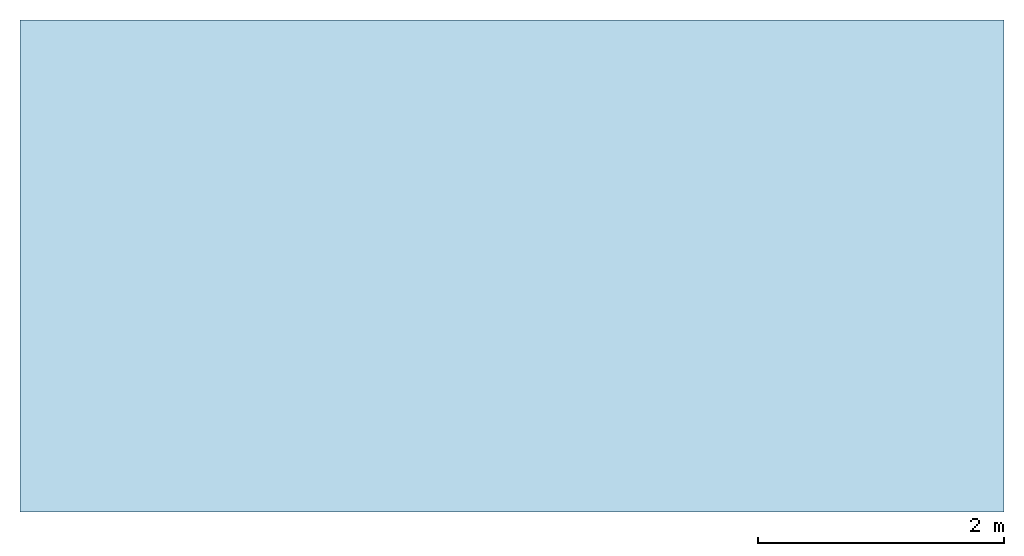
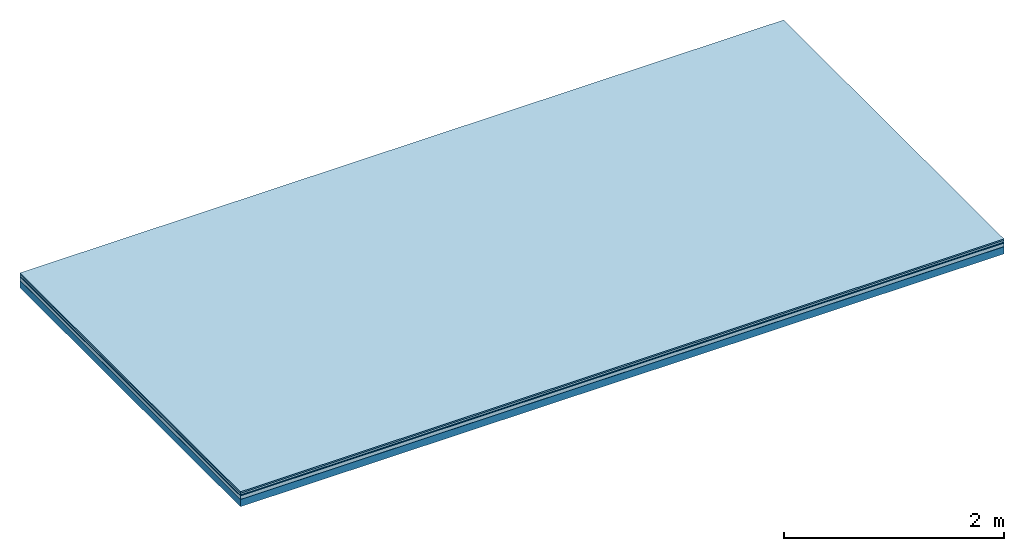
# One storey: 5 plates, 1 member, 1 element without a shape of its own.
"""IFC4 building model written with IfcOpenShell, lengths in metres."""

import ifcopenshell
import ifcopenshell.guid

model = None  # the IFC model being written
_history = None  # IfcOwnerHistory: only IFC2X3 demands one
_inside = {}  # id of a spatial element -> (the spatial element, [elements in it])
_under = {}  # id of a project, library or spatial element -> (it, [spatial elements below it])
_declared = {}  # id of a project -> (the project, [libraries it declares])
_typed = {}  # id of a type object -> (the type object, [elements of that type])
_made_of = {}  # id of a material, layer set ... -> (it, [elements and type objects made of it])


def new_model(schema):
    """Start an empty IFC model of exactly this schema.

    Asked for "IFC4X3", IfcOpenShell would pick the latest addendum, in which some entities
    have other attributes; the version numbers below select the first issue.
    IFC2X3 requires an IfcOwnerHistory on every rooted entity: one is made here for all.
    """
    global model, _history
    if schema == "IFC4X3":
        model = ifcopenshell.file(schema_version=(4, 3, 0, 0))
    else:
        model = ifcopenshell.file(schema=schema)
    _inside.clear()
    _under.clear()
    _declared.clear()
    _typed.clear()
    _made_of.clear()
    _history = None
    if model.schema == "IFC2X3":
        org = make("IfcOrganization", Name="unknown")
        user = make(
            "IfcPersonAndOrganization",
            ThePerson=make("IfcPerson", FamilyName="unknown"),
            TheOrganization=org,
        )
        app = make(
            "IfcApplication",
            ApplicationDeveloper=org,
            Version="unknown",
            ApplicationFullName="unknown",
            ApplicationIdentifier="unknown",
        )
        _history = make(
            "IfcOwnerHistory",
            OwningUser=user,
            OwningApplication=app,
            ChangeAction="ADDED",
            CreationDate=0,
        )
    return model


def make(cls, **values):
    """One entity of the class cls with the attributes given. An attribute that is None is left unset."""
    return model.create_entity(
        cls, **{name: value for name, value in values.items() if value is not None}
    )


def rooted(cls, **values):
    """An entity with a GlobalId (a new one), such as an element, a storey or a relation."""
    return make(cls, GlobalId=ifcopenshell.guid.new(), OwnerHistory=_history, **values)


def si_unit(unit_type, name, prefix=None):
    """IfcSIUnit, for example si_unit("LENGTHUNIT", "METRE", prefix="MILLI")."""
    return make("IfcSIUnit", UnitType=unit_type, Prefix=prefix, Name=name)


def derived_unit(unit_type, elements):
    """IfcDerivedUnit: a product of units, each with its exponent."""
    return make(
        "IfcDerivedUnit",
        Elements=[
            make("IfcDerivedUnitElement", Unit=unit, Exponent=power)
            for unit, power in elements
        ],
        UnitType=unit_type,
    )


def assignment(units):
    """IfcUnitAssignment: the units of a project."""
    return None if units is None else make("IfcUnitAssignment", Units=units)


def point(xyz):
    """IfcCartesianPoint."""
    return None if xyz is None else make("IfcCartesianPoint", Coordinates=xyz)


def direction(xyz):
    """IfcDirection."""
    return None if xyz is None else make("IfcDirection", DirectionRatios=xyz)


def frame(location, z_axis=None, x_axis=None):
    """IfcAxis2Placement3D, a coordinate frame: its origin and axes. An axis left out is left unset."""
    return make(
        "IfcAxis2Placement3D",
        Location=point(location),
        Axis=direction(z_axis),
        RefDirection=direction(x_axis),
    )


def frame_2d(location, x_axis=None):
    """IfcAxis2Placement2D, a coordinate frame in the plane: its origin and x axis."""
    return make(
        "IfcAxis2Placement2D", Location=point(location), RefDirection=direction(x_axis)
    )


def origin():
    """The frame at (0, 0, 0) with its axes left unset."""
    return frame((0.0, 0.0, 0.0))


def origin_with_axes():
    """The frame at (0, 0, 0) with the z axis (0, 0, 1) and the x axis (1, 0, 0) written out."""
    return frame((0.0, 0.0, 0.0), z_axis=(0.0, 0.0, 1.0), x_axis=(1.0, 0.0, 0.0))


def place(relative_to, where):
    """IfcLocalPlacement: puts the frame where relative to a parent placement (None: the world)."""
    return make(
        "IfcLocalPlacement", PlacementRelTo=relative_to, RelativePlacement=where
    )


def context(
    kind, dimensions, precision=None, world=None, true_north=None, identifier=None
):
    """IfcGeometricRepresentationContext, for example the 3D "Model" context."""
    return make(
        "IfcGeometricRepresentationContext",
        ContextIdentifier=identifier,
        ContextType=kind,
        CoordinateSpaceDimension=dimensions,
        Precision=precision,
        WorldCoordinateSystem=world,
        TrueNorth=true_north,
    )


def project(units=None, contexts=None):
    """IfcProject with its units and contexts."""
    return rooted(
        "IfcProject",
        Name="project",
        RepresentationContexts=contexts,
        UnitsInContext=assignment(units),
    )


def spatial(cls, under=None, at=None, **own):
    """A site, building, storey or space (cls), placed at a placement, below another one or the project."""
    s = rooted(cls, ObjectPlacement=at, **own)
    if under is not None:
        _under.setdefault(under.id(), (under, []))[1].append(s)
    return s


def profile(cls, at=None, kind="AREA", **sizes):
    """A parametric profile (cls). Its sizes go by their IFC names, for example OverallWidth=200.0."""
    return make(cls, ProfileType=kind, Position=at, **sizes)


def rectangle(**sizes):
    """IfcRectangleProfileDef."""
    return profile("IfcRectangleProfileDef", **sizes)


def extrude(swept, where, along, depth):
    """IfcExtrudedAreaSolid: the profile swept, set in the frame where, extruded along a direction by depth."""
    return make(
        "IfcExtrudedAreaSolid",
        SweptArea=swept,
        Position=where,
        ExtrudedDirection=direction(along),
        Depth=depth,
    )


def shape(context_of_items, identifier, shape_type, items):
    """IfcShapeRepresentation: the items that make up one representation, for example the "Body"."""
    return make(
        "IfcShapeRepresentation",
        ContextOfItems=context_of_items,
        RepresentationIdentifier=identifier,
        RepresentationType=shape_type,
        Items=items,
    )


def material(Name=None, Category=None):
    """IfcMaterial."""
    return make("IfcMaterial", Name=Name, Category=Category)


def layer(
    of_material, thickness, ventilated=None, Name=None, Category=None, Priority=None
):
    """IfcMaterialLayer: one layer of a wall or slab, of a material (None: an air gap)."""
    return make(
        "IfcMaterialLayer",
        Material=of_material,
        LayerThickness=thickness,
        IsVentilated=ventilated,
        Name=Name,
        Category=Category,
        Priority=Priority,
    )


def layer_set(layers, Name=None):
    """IfcMaterialLayerSet."""
    return make("IfcMaterialLayerSet", MaterialLayers=layers, LayerSetName=Name)


def made_of(thing, what):
    """Note that an element or type object is made of a material, layer set ...; save() writes the relation."""
    if what is not None:
        _made_of.setdefault(what.id(), (what, []))[1].append(thing)
    return thing


def type_object(cls, material=None, **own):
    """A type object (cls), such as IfcWallType, which elements share."""
    return made_of(rooted(cls, **own), material)


def element(
    cls,
    number,
    at=None,
    inside=None,
    cuts=None,
    type_object=None,
    material=None,
    context=None,
    identifier="Body",
    shape_type=None,
    held_by="IfcProductDefinitionShape",
    body=None,
    shapes=None,
    **own,
):
    """One element of the class cls, such as IfcWall. Its Tag is "e" and its number.

    at: its placement. inside: the storey or other place that contains it. cuts: it is an
    opening in that element (IfcRelVoidsElement). A single representation is given by context,
    identifier, shape_type and body (its items); several are given by shapes. held_by: the class
    of the entity that holds the representations. save() writes the other relations.
    """
    e = rooted(cls, Tag="e%d" % number, ObjectPlacement=at, **own)
    if body is not None:
        shapes = [shape(context, identifier, shape_type, body)]
    if shapes is not None:
        e.Representation = make(held_by, Representations=shapes)
    if inside is not None:
        _inside.setdefault(inside.id(), (inside, []))[1].append(e)
    if cuts is not None:
        rooted(
            "IfcRelVoidsElement", RelatingBuildingElement=cuts, RelatedOpeningElement=e
        )
    if type_object is not None:
        _typed.setdefault(type_object.id(), (type_object, []))[1].append(e)
    return made_of(e, material)


def aggregate(whole, parts):
    """IfcRelAggregates: a whole, such as a stair, and the parts it consists of."""
    return rooted("IfcRelAggregates", RelatingObject=whole, RelatedObjects=parts)


def save(model, path):
    """Write the relations noted so far, then the file.

    IfcRelAggregates (storeys below a building ...), IfcRelContainedInSpatialStructure (elements
    in a storey), IfcRelDefinesByType, IfcRelAssociatesMaterial and IfcRelDeclares: one each for
    every whole, place, type object, material and project.
    """
    for whole, parts in _under.values():
        aggregate(whole, parts)
    for where, things in _inside.values():
        rooted(
            "IfcRelContainedInSpatialStructure",
            RelatedElements=things,
            RelatingStructure=where,
        )
    for kind, things in _typed.values():
        rooted("IfcRelDefinesByType", RelatedObjects=things, RelatingType=kind)
    for what, things in _made_of.values():
        rooted("IfcRelAssociatesMaterial", RelatedObjects=things, RelatingMaterial=what)
    for by, libraries in _declared.values():
        rooted("IfcRelDeclares", RelatingContext=by, RelatedDefinitions=libraries)
    model.write(path)


model = new_model("IFC4")

# Units and contexts
plan_context = context("Plan", 3, precision=1e-05, world=origin(), true_north=direction((0.0, 1.0)))
model_context = context("Model", 3, precision=1e-05, world=origin(), true_north=direction((0.0, 1.0)))
ifc_project = project(units=[si_unit("LENGTHUNIT", "METRE"), derived_unit("SOUNDPRESSUREUNIT", [(si_unit("PRESSUREUNIT", "PASCAL", prefix="MICRO"), 0)]), si_unit("ENERGYUNIT", "JOULE", prefix="MEGA"), si_unit("MASSUNIT", "GRAM", prefix="KILO"), derived_unit("THERMALTRANSMITTANCEUNIT", [(si_unit("POWERUNIT", "WATT"), 1), (si_unit("AREAUNIT", "SQUARE_METRE"), -1), (si_unit("THERMODYNAMICTEMPERATUREUNIT", "KELVIN"), -1)]), derived_unit("AREADENSITYUNIT", [(si_unit("MASSUNIT", "GRAM", prefix="KILO"), 1), (si_unit("AREAUNIT", "SQUARE_METRE"), -1)]), derived_unit("USERDEFINED", [(si_unit("ENERGYUNIT", "JOULE", prefix="MEGA"), 1), (si_unit("AREAUNIT", "SQUARE_METRE"), -1)])], contexts=[plan_context, model_context])

# Site, building, storey
site = spatial("IfcSite", under=ifc_project)
building_placement = place(None, origin())
building = spatial("IfcBuilding", under=site, at=building_placement)
storey_placement = place(building_placement, origin())
storey = spatial("IfcBuildingStorey", under=building, at=storey_placement)

# Slab, member, plates
ifc_material_1 = material(Category="11.013")
ifc_layer_1 = layer(ifc_material_1, 0.015, Name="Flooring")
ifc_material_2 = material(Category="03.007")
ifc_layer_2 = layer(ifc_material_2, 0.02, Name="On-material")
ifc_material_3 = material(Name="Wood fiber generic product", Category="10.009")
ifc_layer_3 = layer(ifc_material_3, 0.01, Name="Impact sound insulation")
ifc_material_4 = material(Name="Cement panels, glued on sub-floor", Category="02.007")
ifc_layer_4 = layer(ifc_material_4, 0.04, Name="on Supporting structure")
ifc_material_5 = material(Name="protection", Category="09.007")
ifc_layer_5 = layer(ifc_material_5, 0.0005, Name="Sub-floor")
ifc_material_6 = material(Name="no composite action")
ifc_layer_6 = layer(ifc_material_6, 0.0, Name="Bond")
ifc_layer_7 = layer(None, 0.08, Name="Supporting structure")
ifc_layer_set = layer_set([ifc_layer_1, ifc_layer_2, ifc_layer_3, ifc_layer_4, ifc_layer_5, ifc_layer_6, ifc_layer_7])
slab_type = type_object("IfcSlabType", Name="A2058", PredefinedType="NOTDEFINED", material=ifc_layer_set)
slab_placement = place(None, frame((0.0, 0.0, 0.0), z_axis=(0.0, 0.0, -1.0), x_axis=(1.0, 0.0, 0.0)))
slab = element("IfcSlab", 1, at=slab_placement, inside=storey, type_object=slab_type, material=ifc_layer_set, Name="Slab #1")
ifc_material_7 = material(Name="Solid timber panel")
member_placement = place(slab_placement, origin())
member = element("IfcMember", 2, at=member_placement, material=ifc_material_7, Name="Supporting structure", context=plan_context, shape_type="SweptSolid", body=[
    extrude(rectangle(XDim=1.0, YDim=0.08, at=frame_2d((0.5, 0.04), x_axis=(1.0, 0.0))), frame((0.0, 4.0, 0.0855), z_axis=(0.0, -1.0, 0.0), x_axis=(1.0, 0.0, 0.0)), (0.0, 0.0, 1.0), 4.0),
    extrude(rectangle(XDim=1.0, YDim=0.08, at=frame_2d((0.5, 0.04), x_axis=(1.0, 0.0))), frame((1.0, 4.0, 0.0855), z_axis=(0.0, -1.0, 0.0), x_axis=(1.0, 0.0, 0.0)), (0.0, 0.0, 1.0), 4.0),
    extrude(rectangle(XDim=1.0, YDim=0.08, at=frame_2d((0.5, 0.04), x_axis=(1.0, 0.0))), frame((2.0, 4.0, 0.0855), z_axis=(0.0, -1.0, 0.0), x_axis=(1.0, 0.0, 0.0)), (0.0, 0.0, 1.0), 4.0),
    extrude(rectangle(XDim=1.0, YDim=0.08, at=frame_2d((0.5, 0.04), x_axis=(1.0, 0.0))), frame((3.0, 4.0, 0.0855), z_axis=(0.0, -1.0, 0.0), x_axis=(1.0, 0.0, 0.0)), (0.0, 0.0, 1.0), 4.0),
    extrude(rectangle(XDim=1.0, YDim=0.08, at=frame_2d((0.5, 0.04), x_axis=(1.0, 0.0))), frame((4.0, 4.0, 0.0855), z_axis=(0.0, -1.0, 0.0), x_axis=(1.0, 0.0, 0.0)), (0.0, 0.0, 1.0), 4.0),
    extrude(rectangle(XDim=1.0, YDim=0.08, at=frame_2d((0.5, 0.04), x_axis=(1.0, 0.0))), frame((5.0, 4.0, 0.0855), z_axis=(0.0, -1.0, 0.0), x_axis=(1.0, 0.0, 0.0)), (0.0, 0.0, 1.0), 4.0),
    extrude(rectangle(XDim=1.0, YDim=0.08, at=frame_2d((0.5, 0.04), x_axis=(1.0, 0.0))), frame((6.0, 4.0, 0.0855), z_axis=(0.0, -1.0, 0.0), x_axis=(1.0, 0.0, 0.0)), (0.0, 0.0, 1.0), 4.0),
    extrude(rectangle(XDim=1.0, YDim=0.08, at=frame_2d((0.5, 0.04), x_axis=(1.0, 0.0))), frame((7.0, 4.0, 0.0855), z_axis=(0.0, -1.0, 0.0), x_axis=(1.0, 0.0, 0.0)), (0.0, 0.0, 1.0), 4.0),
])
plate_1_placement = place(slab_placement, origin())
plate_1 = element("IfcPlate", 3, at=plate_1_placement, material=ifc_material_1, Name="Flooring", context=plan_context, shape_type="SweptSolid", body=[
    extrude(rectangle(XDim=8.0, YDim=4.0, at=frame_2d((4.0, 2.0), x_axis=(1.0, 0.0))), origin_with_axes(), (0.0, 0.0, 1.0), 0.015),
])
plate_2_placement = place(slab_placement, origin())
plate_2 = element("IfcPlate", 4, at=plate_2_placement, material=ifc_material_2, Name="On-material", context=plan_context, shape_type="SweptSolid", body=[
    extrude(rectangle(XDim=8.0, YDim=4.0, at=frame_2d((4.0, 2.0), x_axis=(1.0, 0.0))), frame((0.0, 0.0, 0.015), z_axis=(0.0, 0.0, 1.0), x_axis=(1.0, 0.0, 0.0)), (0.0, 0.0, 1.0), 0.02),
])
plate_3_placement = place(slab_placement, origin())
plate_3 = element("IfcPlate", 5, at=plate_3_placement, material=ifc_material_3, Name="Impact sound insulation", context=plan_context, shape_type="SweptSolid", body=[
    extrude(rectangle(XDim=8.0, YDim=4.0, at=frame_2d((4.0, 2.0), x_axis=(1.0, 0.0))), frame((0.0, 0.0, 0.035), z_axis=(0.0, 0.0, 1.0), x_axis=(1.0, 0.0, 0.0)), (0.0, 0.0, 1.0), 0.01),
])
plate_4_placement = place(slab_placement, origin())
plate_4 = element("IfcPlate", 6, at=plate_4_placement, material=ifc_material_4, Name="on Supporting structure", context=plan_context, shape_type="SweptSolid", body=[
    extrude(rectangle(XDim=8.0, YDim=4.0, at=frame_2d((4.0, 2.0), x_axis=(1.0, 0.0))), frame((0.0, 0.0, 0.045), z_axis=(0.0, 0.0, 1.0), x_axis=(1.0, 0.0, 0.0)), (0.0, 0.0, 1.0), 0.04),
])
plate_5_placement = place(slab_placement, origin())
plate_5 = element("IfcPlate", 7, at=plate_5_placement, material=ifc_material_5, Name="Sub-floor", context=plan_context, shape_type="SweptSolid", body=[
    extrude(rectangle(XDim=8.0, YDim=4.0, at=frame_2d((4.0, 2.0), x_axis=(1.0, 0.0))), frame((0.0, 0.0, 0.085), z_axis=(0.0, 0.0, 1.0), x_axis=(1.0, 0.0, 0.0)), (0.0, 0.0, 1.0), 0.0005),
])
aggregate(slab, [plate_1, plate_2, plate_3, plate_4, plate_5, member])

save(model, "model.ifc")
